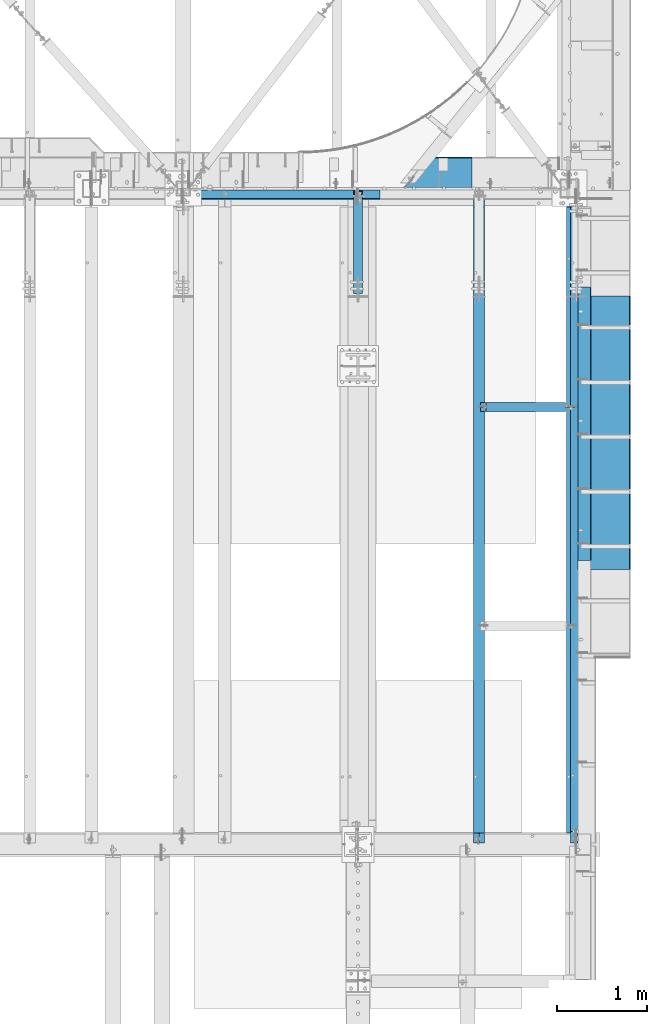
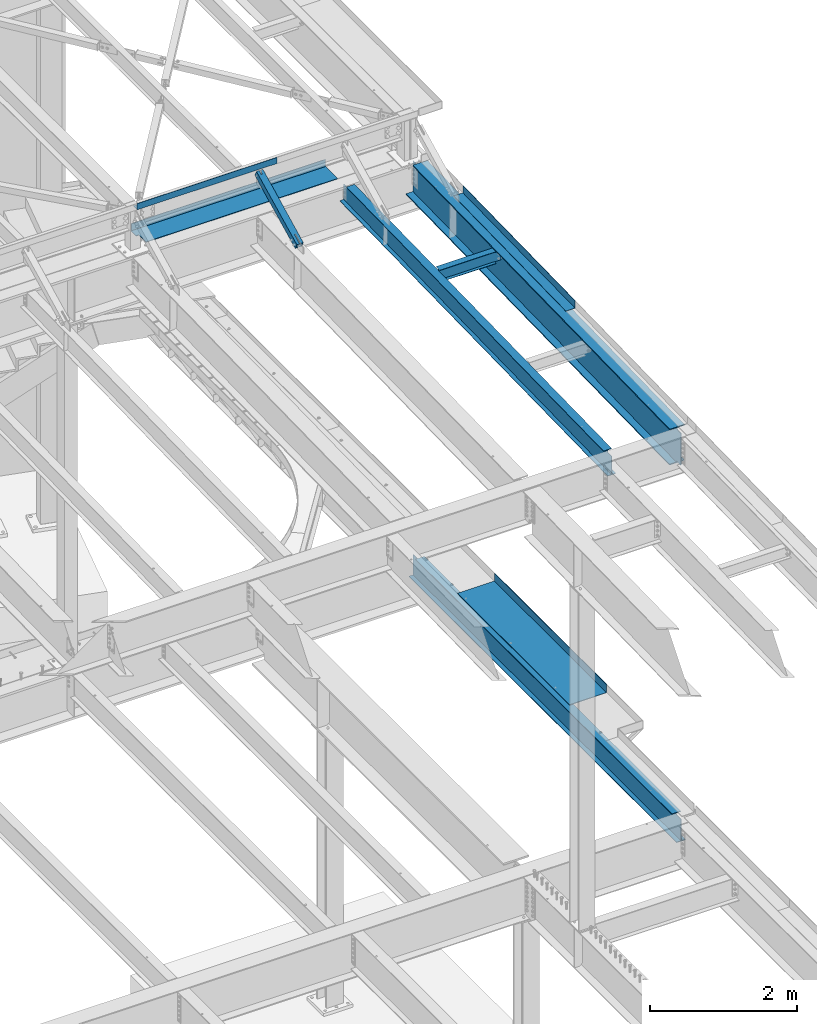
# One storey, part 1164 of 1763: 8 beams, 1 member, 7 elements without a shape of their own.
"""IFC2X3 building model written with IfcOpenShell, lengths in millimetres."""

from ifc_helpers import new_model, si_unit, frame, origin_with_axes, place, context, subcontext, project, spatial, faceted_brep, material, type_object, element, aggregate, save


model = new_model("IFC2X3")

# Units and contexts
model_context = context("Model", 3, precision=1e-05, world=origin_with_axes())
body_context = subcontext(model_context, "Body", "Model", "MODEL_VIEW")
ifc_project = project(units=[si_unit("LENGTHUNIT", "METRE", prefix="MILLI"), si_unit("AREAUNIT", "SQUARE_METRE"), si_unit("VOLUMEUNIT", "CUBIC_METRE"), si_unit("MASSUNIT", "GRAM", prefix="KILO"), si_unit("TIMEUNIT", "SECOND"), si_unit("PLANEANGLEUNIT", "RADIAN"), si_unit("SOLIDANGLEUNIT", "STERADIAN"), si_unit("THERMODYNAMICTEMPERATUREUNIT", "DEGREE_CELSIUS"), si_unit("LUMINOUSINTENSITYUNIT", "LUMEN")], contexts=[model_context])

# Site, building, storey
site_placement = place(None, origin_with_axes())
site = spatial("IfcSite", under=ifc_project, at=site_placement, CompositionType="ELEMENT")
building_placement = place(site_placement, origin_with_axes())
building = spatial("IfcBuilding", under=site, at=building_placement, Name="Undefined", CompositionType="ELEMENT")
storey_placement = place(building_placement, origin_with_axes())
storey = spatial("IfcBuildingStorey", under=building, at=storey_placement, Name="Undefined", CompositionType="ELEMENT", Elevation=0.0)

# Assembly, beam
assembly_1_placement = place(storey_placement, origin_with_axes())
assembly_1 = element("IfcElementAssembly", 1, at=assembly_1_placement, inside=storey, Name="BEAM", AssemblyPlace="NOTDEFINED", PredefinedType="RIGID_FRAME")
ifc_material_1 = material(Name="STEEL/A36")
beam_type_1 = type_object("IfcBeamType", Name="L4X4X1/4", PredefinedType="NOTDEFINED")
beam_1_placement = place(assembly_1_placement, frame((-25976.6096174484, 52050.95, 12496.8), z_axis=(0.0, 1.0, 0.0), x_axis=(1.0, 0.0, 0.0)))
beam_1 = element("IfcBeam", 2, at=beam_1_placement, type_object=beam_type_1, material=ifc_material_1, Name="V. BRACE", ObjectType="L4X4X1/4", context=body_context, shape_type="Brep", body=[
    faceted_brep([(-3.63797880709171e-11, 50.8000000000011, -50.8000000000538), (-1.96450855582952e-10, 50.8000000000393, 50.7999999999374), (2193.766250002, 50.7999999999993, 50.8000000000029), (2193.766250002, 50.7999999999993, -50.8000000000029), (-1.81898940354586e-10, 44.4500000000371, 50.7999999999374), (2193.766250002, 44.4500000000007, 50.8000000000029), (-2.18278728425503e-11, 44.4500000000007, -44.450000000048), (2193.766250002, 44.4500000000007, -44.4499999999971), (1.96450855582952e-10, -50.8000000000338, -44.4499999999534), (2193.766250002, -50.7999999999993, -44.4499999999971), (2.11002770811319e-10, -50.8000000000357, -50.799999999952), (2193.766250002, -50.7999999999993, -50.8000000000029)], [[[0, 1, 2, 3]], [[1, 4, 5, 2]], [[4, 6, 7, 5]], [[6, 8, 9, 7]], [[8, 10, 11, 9]], [[10, 0, 3, 11]], [[5, 7, 9, 11, 3, 2]], [[10, 8, 6, 4, 1, 0]]]),
])
aggregate(assembly_1, [beam_1])

assembly_2_placement = place(storey_placement, origin_with_axes())
assembly_2 = element("IfcElementAssembly", 3, at=assembly_2_placement, inside=storey, Name="BEAM", AssemblyPlace="NOTDEFINED", PredefinedType="RIGID_FRAME")
beam_type_2 = type_object("IfcBeamType", PredefinedType="NOTDEFINED")
beam_2_placement = place(assembly_2_placement, frame((-21576.7372736984, 49396.65, 5199.0625), z_axis=(0.0, -1.0, 0.0), x_axis=(1.0, 0.0, 0.0)))
beam_2 = element("IfcBeam", 4, at=beam_2_placement, type_object=beam_type_2, material=ifc_material_1, Name="BENT_PLATE", context=body_context, shape_type="Brep", body=[
    faceted_brep([(0.0, -4.76249999999982, -1524.0), (0.0, -4.76249999999982, 1524.0), (0.0, 4.76249999999982, 1524.0), (0.0, 4.76249999999982, -1524.0), (577.849999999999, 4.76249999999982, 1524.0), (577.849999999999, 4.76249999999982, -1524.0), (587.375, -4.76249999999982, -1524.0), (587.375, -4.76249999999982, 1524.0), (577.849999999999, 134.937496948242, 1524.0), (577.849999999999, 134.937496948242, -1524.0), (587.375, 134.937496948242, 1524.0), (587.375, 134.937496948242, -1524.0)], [[[0, 1, 2, 3]], [[3, 2, 4, 5]], [[1, 0, 6, 7]], [[5, 4, 8, 9]], [[4, 2, 1, 7, 10, 8]], [[7, 6, 11, 10]], [[6, 0, 3, 5, 9, 11]], [[10, 11, 9, 8]]]),
])

assembly_3_placement = place(storey_placement, origin_with_axes())
assembly_3 = element("IfcElementAssembly", 5, at=assembly_3_placement, inside=storey, Name="BEAM", AssemblyPlace="NOTDEFINED", PredefinedType="RIGID_FRAME")
ifc_material_2 = material(Name="STEEL/A992")
beam_type_3 = type_object("IfcBeamType", Name="W8X10", PredefinedType="NOTDEFINED")
beam_3_placement = place(assembly_3_placement, frame((-22673.3396174483, 49682.4, 11597.037837497), z_axis=(0.0, 0.0, 1.0), x_axis=(1.0, 0.0, 0.0)))
beam_3 = element("IfcBeam", 6, at=beam_3_placement, type_object=beam_type_3, material=ifc_material_2, Name="BEAM", ObjectType="W8X10", context=body_context, shape_type="Brep", body=[
    faceted_brep([(957.692640135556, 2.6814562411455, -95.25), (957.692640136163, 2.6810410749822, -100.012500000001), (957.692569353068, 50.8000000000029, -100.012500000001), (957.692569353068, 50.8000000000029, -95.25), (1065.64272309272, 2.68161503600277, -95.25), (1065.64272309272, 2.6811998698322, -100.012500000001), (74.2523437499622, 2.38124999999854, 95.25), (74.2523437499622, 50.8000000000029, 95.25), (956.898971566847, 50.8000000000029, 95.25), (956.898971566847, 2.38124999999854, 95.25), (74.2523437499622, -50.8000000000029, 100.012500000001), (74.2523437499622, 50.8000000000029, 100.012500000001), (74.2523437499622, 2.38124999999854, 80.7025014875653), (74.2523437499622, -2.38124999999854, 80.7025014875653), (74.2523437499622, -2.38124999999854, 95.25), (74.2523437499622, -50.8000000000029, 95.25), (73.2856138273746, 2.38124999999854, 75.8424219695189), (73.2856138273746, -2.38124999999854, 75.8424219695189), (70.5325999268971, 2.38124999999854, 71.7222455013653), (70.5325999268971, -2.38124999999854, 71.7222455013653), (66.4124234587434, 2.38124999999854, 68.9692316008877), (66.4124234587434, -2.38124999999854, 68.9692316008877), (61.552343940697, 2.38124999999854, 68.0025016783002), (61.552343940697, -2.38124999999854, 68.0025016783002), (10.7523437499694, 2.38124999999854, 68.0025016783002), (10.7523437499694, -2.38124999999854, 68.0025016783002), (10.7523437499694, 2.38124999999854, -95.25), (10.7523437499694, 50.8000000000029, -95.25), (10.7523437499694, 50.8000000000029, -100.012500000001), (10.7523437499694, -50.8000000000029, -100.012500000001), (10.7523437499694, -50.8000000000029, -95.25), (10.7523437499694, -2.38124999999854, -95.25), (957.692715737423, -50.8000000000029, -100.012500000001), (957.692715737423, -50.8000000000029, -95.25), (957.692644955085, -2.68145587174513, -100.012500000001), (957.692644954477, -2.68104070558184, -95.25), (1065.64272309272, -2.68088191115385, -95.25), (1065.64272309272, -2.68129707733169, -100.012500000001), (1065.64272309272, -2.38124999999854, -95.25), (969.598971376112, -2.38124999999854, 50.7402008918289), (965.540739476481, -2.38124999999854, 51.5474334063601), (964.738891858065, -2.38124999999854, 51.7069308144164), (960.618715389912, -2.38124999999854, 54.4599447148939), (957.865701489434, -2.38124999999854, 58.5801211830476), (956.898971566847, -2.38124999999854, 63.440200701094), (956.898971566847, -2.38124999999854, 95.25), (1065.64272309272, -2.38124999999854, 50.7402008918289), (970.392722901983, -2.38124999999854, 50.7402008918289), (956.898971566847, -50.8000000000029, 95.25), (956.898971566847, -50.8000000000029, 100.012500000001), (956.898971566847, 50.8000000000029, 100.012500000001), (956.898971566847, 2.38124999999854, 63.440200701094), (957.865701489434, 2.38124999999854, 58.5801211830476), (960.618715389912, 2.38124999999854, 54.4599447148939), (964.738891858065, 2.38124999999854, 51.7069308144164), (969.598971376112, 2.38124999999854, 50.7402008918289), (965.540739476481, 2.38124999999854, 51.5474334063601), (1065.64272309272, 2.38124999999854, 50.7402008918289), (970.392722901983, 2.38124999999854, 50.7402008918289), (1065.64272309272, 2.38124999999854, -95.25)], [[[0, 1, 2, 3]], [[4, 5, 1, 0]], [[6, 7, 8, 9]], [[10, 11, 7, 6, 12, 13, 14, 15]], [[13, 12, 16, 17]], [[17, 16, 18, 19]], [[19, 18, 20, 21]], [[21, 20, 22, 23]], [[23, 22, 24, 25]], [[26, 27, 28, 29, 30, 31, 25, 24]], [[30, 29, 32, 33]], [[33, 32, 34, 35]], [[36, 35, 34, 37]], [[38, 31, 30, 33, 35, 36]], [[39, 40, 41, 42, 43, 44, 45, 14, 13, 17, 19, 21, 23, 25, 31, 38, 46, 47]], [[15, 14, 45, 48]], [[10, 15, 48, 49]], [[11, 10, 49, 50]], [[7, 11, 50, 8]], [[49, 48, 45, 44, 51, 9, 8, 50]], [[43, 52, 51, 44]], [[42, 53, 52, 43]], [[41, 54, 53, 42]], [[40, 39, 55, 56, 54, 41]], [[47, 46, 57, 58, 55, 39]], [[57, 59, 26, 24, 22, 20, 18, 16, 12, 6, 9, 51, 52, 53, 54, 56, 55, 58]], [[3, 27, 26, 59, 4, 0]], [[28, 27, 3, 2]], [[37, 34, 32, 29, 28, 2, 1, 5]], [[59, 57, 46, 38, 36, 37, 5, 4]]]),
])
aggregate(assembly_3, [beam_3])

# Assembly, member
assembly_4_placement = place(storey_placement, origin_with_axes())
assembly_4 = element("IfcElementAssembly", 7, at=assembly_4_placement, inside=storey, Name="BEAM", AssemblyPlace="NOTDEFINED", PredefinedType="RIGID_FRAME")
ifc_material_3 = material()
member_type = type_object("IfcMemberType", Name="HSS4X4X1/2", PredefinedType="NOTDEFINED")
member_placement = place(assembly_4_placement, frame((-24027.8372736984, 50822.4762411266, 11720.6381213768), z_axis=(-1.0, 0.0, 0.0), x_axis=(0.0, 0.894427191199916, 0.447213595099959)))
member = element("IfcMember", 8, at=member_placement, type_object=member_type, material=ifc_material_3, Name="BEAM", ObjectType="HSS4X4X1/2", context=body_context, shape_type="Brep", body=[
    faceted_brep([(1394.22226894295, -50.8000000020184, -7.9375), (1394.2222689429, -38.1000000020122, -7.9375), (1321.53025774739, -38.1000000019103, -7.9375), (1327.88025774027, -50.8000000019219, -7.9375), (1321.53025774739, -38.1000000019103, 7.9375), (1327.88025774027, -50.8000000019219, 7.9375), (1394.22226894295, -50.8000000020184, 7.9375), (1394.2222689429, -38.1000000020122, 7.9375), (1394.22226894266, 38.0999999980304, -7.9375), (1394.22226894262, 50.799999998042, -7.9375), (1277.08025779721, 50.7999999982076, -7.9375), (1283.4302577901, 38.0999999981887, -7.9375), (1277.08025779721, 50.7999999982076, 7.9375), (1283.4302577901, 38.0999999981887, 7.9375), (1394.22226894266, 38.0999999980304, 7.9375), (1394.22226894262, 50.799999998042, 7.9375), (166.342448712407, -38.100000000255, 38.0999999999985), (166.342448712276, 38.0999999997875, 38.0999999999985), (1394.22226894266, 38.0999999980304, 38.0999999999985), (1394.2222689429, -38.1000000020122, 38.0999999999985), (1394.2222689429, -38.1000000020122, -38.0999999999985), (166.342448712407, -38.100000000255, -38.0999999999985), (166.342448712407, -38.100000000255, -7.93749999974898), (317.154945941751, -38.1000000004715, -7.93749999987267), (320.192495686126, -38.1000000004769, -7.33329378918279), (322.767606017376, -38.1000000004806, -5.61266007554514), (324.488239731007, -38.1000000004842, -3.03754974427284), (325.092445941693, -38.1000000004842, 2.5465851649642e-10), (324.488239731007, -38.1000000004842, 3.03754974465119), (322.767606017376, -38.1000000004806, 5.61266007592349), (320.192495686126, -38.1000000004788, 7.33329378956478), (317.154945941751, -38.1000000004733, 7.93750000025466), (166.342448712407, -38.100000000255, 7.93750000025466), (166.342448712276, 38.0999999997875, -38.0999999999985), (1394.22226894266, 38.0999999980304, -38.0999999999985), (166.342448712276, 38.0999999997875, 7.93750000025466), (166.342448712254, 50.7999999997955, 7.93750000025466), (317.154945941591, 50.7999999995791, 7.93750000025466), (317.15494594162, 38.0999999995711, 7.93750000025466), (320.192495685966, 50.7999999995736, 7.33329378956478), (320.192495685995, 38.0999999995693, 7.33329378956478), (322.767606017216, 50.7999999995718, 5.61266007592349), (322.767606017245, 38.0999999995638, 5.61266007592349), (324.488239730847, 50.7999999995682, 3.03754974465119), (324.488239730868, 38.0999999995638, 3.03754974465119), (325.092445941533, 50.7999999995682, 2.5465851649642e-10), (325.092445941555, 38.0999999995583, 2.5465851649642e-10), (324.488239730847, 50.7999999995682, -3.03754974427284), (324.488239730861, 38.0999999995602, -3.03754974427284), (322.767606017209, 50.79999999957, -5.61266007554514), (322.767606017245, 38.0999999995638, -5.61266007554514), (320.192495685966, 50.7999999995754, -7.33329378918279), (320.19249568598, 38.0999999995674, -7.33329378918279), (317.154945941591, 50.7999999995791, -7.93749999987267), (317.154945941606, 38.0999999995693, -7.93749999987267), (166.342448712254, 50.7999999997955, -7.93749999974898), (166.342448712276, 38.0999999997875, -7.93749999974898), (166.342448712254, 50.7999999997955, -50.7999999999993), (166.342448712421, -50.8000000002612, -50.7999999999993), (166.342448712421, -50.8000000002612, -7.93749999974898), (317.154945941773, -50.8000000004795, -7.93749999987267), (320.192495686155, -50.8000000004831, -7.33329378918279), (322.767606017391, -50.8000000004868, -5.61266007554514), (324.488239731028, -50.800000000494, -3.03754974427284), (325.092445941715, -50.8000000004904, 2.5465851649642e-10), (324.488239731028, -50.800000000494, 3.03754974465119), (322.767606017405, -50.8000000004849, 5.61266007592349), (320.192495686155, -50.8000000004849, 7.33329378956478), (317.154945941787, -50.8000000004795, 7.93750000025466), (166.342448712421, -50.8000000002612, 7.93750000025466), (166.342448712421, -50.8000000002612, 50.7999999999993), (166.342448712254, 50.7999999997955, 50.7999999999993), (1394.22226894295, -50.8000000020184, 50.7999999999993), (1394.22226894262, 50.799999998042, 50.7999999999993), (1394.22226894262, 50.799999998042, -50.7999999999993), (1394.22226894295, -50.8000000020184, -50.7999999999993)], [[[0, 1, 2, 3]], [[3, 2, 4, 5]], [[6, 5, 4, 7]], [[8, 9, 10, 11]], [[11, 10, 12, 13]], [[14, 13, 12, 15]], [[16, 17, 18, 19]], [[2, 1, 20, 21, 22, 23, 24, 25, 26, 27, 28, 29, 30, 31, 32, 16, 19, 7, 4]], [[33, 21, 20, 34]], [[35, 36, 37, 38]], [[38, 37, 39, 40]], [[40, 39, 41, 42]], [[42, 41, 43, 44]], [[44, 43, 45, 46]], [[46, 45, 47, 48]], [[48, 47, 49, 50]], [[50, 49, 51, 52]], [[52, 51, 53, 54]], [[54, 53, 55, 56]], [[21, 33, 56, 55, 57, 58, 59, 22]], [[60, 23, 22, 59]], [[61, 24, 23, 60]], [[62, 25, 24, 61]], [[63, 26, 25, 62]], [[64, 27, 26, 63]], [[65, 28, 27, 64]], [[66, 29, 28, 65]], [[67, 30, 29, 66]], [[68, 31, 30, 67]], [[69, 32, 31, 68]], [[70, 71, 36, 35, 17, 16, 32, 69]], [[71, 70, 72, 73]], [[19, 18, 14, 15, 73, 72, 6, 7]], [[10, 9, 74, 57, 55, 53, 51, 49, 47, 45, 43, 41, 39, 37, 36, 71, 73, 15, 12]], [[58, 57, 74, 75]], [[72, 70, 69, 68, 67, 66, 65, 64, 63, 62, 61, 60, 59, 58, 75, 0, 3, 5, 6]], [[75, 74, 9, 8, 34, 20, 1, 0]], [[18, 17, 35, 38, 40, 42, 44, 46, 48, 50, 52, 54, 56, 33, 34, 8, 11, 13, 14]]]),
])
aggregate(assembly_4, [member])

# Assembly, beam
assembly_5_placement = place(storey_placement, origin_with_axes())
assembly_5 = element("IfcElementAssembly", 9, at=assembly_5_placement, inside=storey, Name="BEAM", AssemblyPlace="NOTDEFINED", PredefinedType="RIGID_FRAME")
beam_type_4 = type_object("IfcBeamType", Name="W14X22", PredefinedType="NOTDEFINED")
beam_4_placement = place(assembly_5_placement, frame((-22678.4622736984, 44809.2121579121, 11421.5633921212), z_axis=(0.0, -0.0206852279954837, 0.999786037781472), x_axis=(0.0, 0.999786037781472, 0.0206852279954825)))
beam_4 = element("IfcBeam", 10, at=beam_4_placement, type_object=beam_type_4, material=ifc_material_2, Name="BEAM", ObjectType="W14X22", context=body_context, shape_type="Brep", body=[
    faceted_brep([(116.24722620719, -3.17499999999927, 136.265001678286), (116.24722620719, 3.17499999999927, 136.265001678286), (17.4665018602245, 3.17499999999927, 136.265001678306), (17.4665018602245, -3.17499999999927, 136.265001678306), (121.10730572528, -3.17499999999927, 137.231731600872), (121.10730572528, 3.17499999999927, 137.231731600872), (125.227482193462, -3.17499999999927, 139.984745501344), (125.227482193462, 3.17499999999927, 139.984745501344), (127.980496093973, -3.17499999999927, 144.104921969487), (127.980496093973, 3.17499999999927, 144.104921969487), (128.947226016564, -3.17499999999927, 148.965001487522), (128.947226016564, 3.17499999999927, 148.965001487522), (128.947226016564, -63.5, 174.624999999836), (128.947226016564, 63.5, 174.624999999836), (128.947226016571, 63.5, 166.687499999842), (128.947226016571, 3.17499999999927, 166.687499999842), (128.947226016571, -3.17499999999927, 166.687499999842), (128.947226016571, -63.5, 166.687499999842), (11.1985191797066, -3.17499999999927, -166.687499999876), (11.1985191797066, -63.5, -166.687499999876), (7286.68019766203, -63.5, -166.687500001812), (7286.68019766203, -3.17499999999927, -166.687500001812), (11.0342950447375, -63.5, -174.624999999869), (7286.51597352705, -63.5, -174.625000001804), (11.0342950447375, 63.5, -174.624999999869), (7286.51597352705, 63.5, -174.625000001804), (11.1985191797066, 63.5, -166.687499999876), (7286.68019766203, 63.5, -166.687500001812), (11.1985191797066, 3.17499999999927, -166.687499999876), (7286.68019766203, 3.17499999999927, -166.687500001812), (7292.02852510755, 3.17499999999927, 91.8149978515976), (7292.02852510755, -3.17499999999927, 91.8149978515976), (7125.028904344, 3.17499999999927, 91.8149978516285), (7125.028904344, -3.17499999999927, 91.8149978516285), (7120.16882482591, 3.17499999999927, 92.7817277742161), (7120.16882482591, -3.17499999999927, 92.7817277742161), (7116.04864835773, 3.17499999999927, 95.5347416746881), (7116.04864835773, -3.17499999999927, 95.5347416746881), (7113.29563445722, 3.17499999999927, 99.6549181428345), (7113.29563445722, -3.17499999999927, 99.6549181428345), (7112.32890453462, 3.17499999999927, 104.51499766087), (7112.32890453462, -3.17499999999927, 104.51499766087), (7112.32890453463, -63.5, 174.624999997979), (7112.32890453462, -63.5, 166.687499997985), (7112.32890453462, -3.17499999999927, 166.687499997985), (7112.32890453462, 3.17499999999927, 166.687499997985), (7112.32890453462, 63.5, 166.687499997985), (7112.32890453463, 63.5, 174.624999997979)], [[[0, 1, 2, 3]], [[4, 5, 1, 0]], [[6, 7, 5, 4]], [[8, 9, 7, 6]], [[10, 11, 9, 8]], [[12, 13, 14, 15, 11, 10, 16, 17]], [[18, 19, 20, 21]], [[19, 22, 23, 20]], [[22, 24, 25, 23]], [[24, 26, 27, 25]], [[26, 28, 29, 27]], [[21, 20, 23, 25, 27, 29, 30, 31]], [[31, 30, 32, 33]], [[33, 32, 34, 35]], [[35, 34, 36, 37]], [[37, 36, 38, 39]], [[39, 38, 40, 41]], [[42, 43, 44, 41, 40, 45, 46, 47]], [[43, 42, 12, 17]], [[44, 43, 17, 16]], [[8, 6, 4, 0, 3, 18, 21, 31, 33, 35, 37, 39, 41, 44, 16, 10]], [[28, 26, 24, 22, 19, 18, 3, 2]], [[45, 40, 38, 36, 34, 32, 30, 29, 28, 2, 1, 5, 7, 9, 11, 15]], [[46, 45, 15, 14]], [[47, 46, 14, 13]], [[42, 47, 13, 12]]]),
])
aggregate(assembly_5, [beam_4])

assembly_6_placement = place(storey_placement, origin_with_axes())
assembly_6 = element("IfcElementAssembly", 11, at=assembly_6_placement, inside=storey, Name="BEAM", AssemblyPlace="NOTDEFINED", PredefinedType="RIGID_FRAME")
beam_type_5 = type_object("IfcBeamType", PredefinedType="NOTDEFINED")
beam_5_placement = place(assembly_6_placement, frame((-24278.6617736984, 52133.5000002128, 11752.2624917654), z_axis=(-1.0, 0.0, 0.0), x_axis=(0.0, 1.0, 0.0)))
beam_5 = element("IfcBeam", 12, at=beam_5_placement, type_object=beam_type_5, material=ifc_material_1, Name="BENT_PLATE", context=body_context, shape_type="Brep", body=[
    faceted_brep([(193.674999999981, -4.76250000000073, 1482.0478521423), (193.674999999981, 4.76250000000073, 1482.0478521423), (0.0, 4.76250000000073, 1482.0478521423), (0.0, -4.76250000000073, 1482.0478521423), (193.674999999974, -4.76250000000073, 1523.99998913571), (193.674999999974, 4.76250000000073, 1524.0), (327.024987792975, -4.76250000000073, -1524.0), (0.0, -4.76249999999982, -1524.0), (0.0, 4.76249999999982, -1524.0), (336.549987792969, 4.76250000000073, -1524.0), (336.549987792969, -122.237499999999, -1524.0), (327.024987792975, -122.237499999999, -1524.0), (336.549987792969, 4.76250000000073, 1524.0), (336.549987792969, -122.237499999999, 1524.0), (327.024987792975, -122.237499999999, 1524.0), (327.024987792967, -4.76250000000073, 1524.00000000001)], [[[0, 1, 2, 3]], [[4, 5, 1, 0]], [[6, 7, 8, 9, 10, 11]], [[9, 12, 13, 10]], [[14, 11, 10, 13]], [[15, 6, 11, 14]], [[3, 7, 6, 15, 4, 0]], [[8, 7, 3, 2]], [[12, 9, 8, 2, 1, 5]], [[15, 14, 13, 12, 5, 4]]]),
])
aggregate(assembly_6, [beam_5])

# Assembly, beams
assembly_7_placement = place(storey_placement, origin_with_axes())
assembly_7 = element("IfcElementAssembly", 13, at=assembly_7_placement, inside=storey, Name="BEAM", AssemblyPlace="NOTDEFINED", PredefinedType="RIGID_FRAME")
beam_type_6 = type_object("IfcBeamType", PredefinedType="NOTDEFINED")
beam_6_placement = place(assembly_7_placement, frame((-21576.7406443556, 49497.3265728792, 11696.3969116519), z_axis=(0.0, -0.999786037781472, -0.0206852279954809), x_axis=(1.0, 0.0, 0.0)))
beam_6 = element("IfcBeam", 14, at=beam_6_placement, type_object=beam_type_6, material=ifc_material_1, Name="BENT_PLATE", context=body_context, shape_type="Brep", body=[
    faceted_brep([(0.0, -3.17499999999927, -1523.99999999999), (0.0, -3.17499999999927, 1524.0), (0.0, 3.17499999999927, 1524.0), (0.0, 3.17499999999927, -1523.99999999999), (142.87500610367, 3.17500000040309, 1524.00000000439), (142.875006103837, 3.17499999959364, -1524.00000000439), (149.225006103836, -3.17500000040127, -1524.00000000439), (149.225006103668, -3.17499999959364, 1524.00000000439), (142.875006103754, 123.824997298818, 1524.00000000437), (142.875006103754, 123.824997298098, -1524.00000000442), (149.225006103752, 123.824997298818, 1524.00000000437), (149.225006103752, 123.824997298098, -1524.00000000442)], [[[0, 1, 2, 3]], [[3, 2, 4, 5]], [[1, 0, 6, 7]], [[5, 4, 8, 9]], [[4, 2, 1, 7, 10, 8]], [[7, 6, 11, 10]], [[6, 0, 3, 5, 9, 11]], [[10, 11, 9, 8]]]),
])
beam_type_7 = type_object("IfcBeamType", Name="W24X76", PredefinedType="NOTDEFINED")
beam_7_placement = place(assembly_7_placement, frame((-21589.4406443556, 44811.8720196139, 11293.0034049881), z_axis=(0.0, -0.0206852279954837, 0.999786037781472), x_axis=(0.0, 0.999786037781472, 0.0206852279954825)))
beam_7 = element("IfcBeam", 15, at=beam_7_placement, type_object=beam_type_7, material=ifc_material_2, Name="BEAM", ObjectType="W24X76", context=body_context, shape_type="Brep", body=[
    faceted_brep([(6.49632960907184, -5.55625000000146, -265.372499999168), (6.49632960907184, 5.55625000000146, -265.372499999168), (113.586795220392, 5.55625000000146, -265.372499999228), (113.586795220392, -5.55625000000146, -265.372499999228), (118.446874738482, 5.55625000000146, -266.339229921816), (118.446874738482, -5.55625000000146, -266.339229921816), (122.567051206664, 5.55625000000146, -269.092243822288), (122.567051206664, -5.55625000000146, -269.092243822288), (125.32006510716, 5.55625000000146, -273.212420290434), (125.32006510716, -5.55625000000146, -273.212420290434), (126.286795029759, -5.55625000000146, -278.07249980847), (126.286795029759, 5.55625000000146, -278.07249980847), (126.286795029759, 5.55625000000146, -285.749999999816), (126.286795029759, 114.299999999999, -285.749999999816), (126.286795029751, 114.299999999999, -303.212499999803), (126.286795029751, -114.299999999999, -303.212499999803), (126.286795029759, -114.299999999999, -285.749999999816), (126.286795029759, -5.55625000000146, -285.749999999816), (126.286795029817, 5.55625000000146, 285.749999999754), (126.286795029817, 114.299999999999, 285.749999999754), (7109.66847354787, 114.299999999999, 285.749999997897), (7109.66847354787, 5.55625000000146, 285.749999997897), (113.58679522045, -5.55625000000146, 264.852501677899), (113.58679522045, 5.55625000000146, 264.852501677899), (17.4665018600936, 5.55625000000146, 264.852501677915), (17.4665018600936, -5.55625000000146, 264.852501677915), (118.446874738533, -5.55625000000146, 265.819231600481), (118.446874738533, 5.55625000000146, 265.819231600481), (122.567051206723, -5.55625000000146, 268.572245500953), (122.567051206723, 5.55625000000146, 268.572245500953), (125.320065107226, -5.55625000000146, 272.692421969095), (125.320065107226, 5.55625000000146, 272.692421969095), (126.286795029824, -5.55625000000146, 277.552501487131), (126.286795029824, 5.55625000000146, 277.552501487131), (126.286795029817, -114.299999999999, 303.212499999741), (126.286795029817, 114.299999999999, 303.212499999741), (126.286795029817, -5.55625000000146, 285.749999999754), (126.286795029817, -114.299999999999, 285.749999999754), (7109.66847354787, -5.55625000000146, 285.749999997897), (7109.66847354787, -114.299999999999, 285.749999997897), (7109.66847354788, -114.299999999999, 303.212499997884), (7109.66847354788, 114.299999999999, 303.212499997884), (7109.66847354787, -5.55625000000146, 233.102497660489), (7109.66847354787, 5.55625000000146, 233.102497660489), (7110.63520347048, -5.55625000000146, 228.242418142454), (7110.63520347048, 5.55625000000146, 228.242418142454), (7113.38821737097, -5.55625000000146, 224.122241674309), (7113.38821737097, 5.55625000000146, 224.122241674309), (7117.50839383915, -5.55625000000146, 221.369227773837), (7117.50839383915, 5.55625000000146, 221.369227773837), (7122.36847335724, -5.55625000000146, 220.402497851248), (7122.36847335724, 5.55625000000146, 220.402497851248), (7292.02852510743, -5.55625000000146, 220.402497851217), (7292.02852510743, 5.55625000000146, 220.402497851217), (7281.55640465069, -5.55625000000146, -285.750000001717), (7281.55640465069, -114.299999999999, -285.750000001717), (7281.19511155374, -114.299999999999, -303.212500001704), (7281.19511155374, 114.299999999999, -303.212500001704), (7281.55640465069, 114.299999999999, -285.750000001717), (7281.55640465069, 5.55625000000146, -285.750000001717)], [[[0, 1, 2, 3]], [[3, 2, 4, 5]], [[5, 4, 6, 7]], [[7, 6, 8, 9]], [[10, 11, 12, 13, 14, 15, 16, 17]], [[9, 8, 11, 10]], [[18, 19, 20, 21]], [[22, 23, 24, 25]], [[26, 27, 23, 22]], [[28, 29, 27, 26]], [[30, 31, 29, 28]], [[32, 33, 31, 30]], [[34, 35, 19, 18, 33, 32, 36, 37]], [[37, 36, 38, 39]], [[34, 37, 39, 40]], [[35, 34, 40, 41]], [[19, 35, 41, 20]], [[40, 39, 38, 42, 43, 21, 20, 41]], [[44, 45, 43, 42]], [[46, 47, 45, 44]], [[48, 49, 47, 46]], [[50, 51, 49, 48]], [[52, 53, 51, 50]], [[54, 55, 56, 57, 58, 59, 53, 52]], [[55, 54, 17, 16]], [[56, 55, 16, 15]], [[57, 56, 15, 14]], [[58, 57, 14, 13]], [[59, 58, 13, 12]], [[6, 4, 2, 1, 24, 23, 27, 29, 31, 33, 18, 21, 43, 45, 47, 49, 51, 53, 59, 12, 11, 8]], [[25, 24, 1, 0]], [[54, 52, 50, 48, 46, 44, 42, 38, 36, 32, 30, 28, 26, 22, 25, 0, 3, 5, 7, 9, 10, 17]]]),
])
aggregate(assembly_7, [beam_6, beam_7])

# Beam
beam_type_8 = type_object("IfcBeamType", Name="W16X31", PredefinedType="NOTDEFINED")
beam_8_placement = place(assembly_2_placement, frame((-21589.4372736984, 44805.6, 4992.6875), z_axis=(0.0, 0.0, 1.0), x_axis=(0.0, 1.0, 0.0)))
beam_8 = element("IfcBeam", 16, at=beam_8_placement, type_object=beam_type_8, material=ifc_material_2, Name="BEAM", ObjectType="W16X31", context=body_context, shape_type="Brep", body=[
    faceted_brep([(133.349999433754, -3.17499999999927, 169.602501678466), (133.349999433754, 3.17499999999927, 169.602501678466), (19.0499999999956, 3.17499999999927, 169.602501678466), (19.0499999999956, -3.17499999999927, 169.602501678466), (138.210078951801, -3.17499999999927, 170.569231601054), (138.210078951801, 3.17499999999927, 170.569231601054), (142.330255419954, -3.17499999999927, 173.322245501532), (142.330255419954, 3.17499999999927, 173.322245501532), (145.083269320428, -3.17499999999927, 177.442421969686), (145.083269320428, 3.17499999999927, 177.442421969686), (146.04999924302, -3.17499999999927, 182.302501487731), (146.04999924302, 3.17499999999927, 182.302501487731), (146.04999924302, -69.8499999999985, 201.6125), (146.04999924302, 69.8499999999985, 201.6125), (146.04999924302, 69.8499999999985, 190.5), (146.04999924302, 3.17499999999927, 190.5), (146.04999924302, -3.17499999999927, 190.5), (146.04999924302, -69.8499999999985, 190.5), (19.0499999999956, -3.17499999999927, -190.5), (19.0499999999956, -69.8499999999985, -190.5), (7292.18125, -69.8499999999985, -190.5), (7292.18125, -3.17499999999927, -190.5), (19.0499999999956, -69.8499999999985, -201.6125), (7292.18125, -69.8499999999985, -201.6125), (19.0499999999956, 69.8499999999985, -201.6125), (7292.18125, 69.8499999999985, -201.6125), (19.0499999999956, 69.8499999999985, -190.5), (7292.18125, 69.8499999999985, -190.5), (19.0499999999956, 3.17499999999927, -190.5), (7292.18125, 3.17499999999927, -190.5), (7292.18125, 3.17499999999927, 144.202497863769), (7292.18125, -3.17499999999927, 144.202497863769), (7120.73124980927, 3.17499999999927, 144.202497863769), (7120.73124980927, -3.17499999999927, 144.202497863769), (7115.87117029122, 3.17499999999927, 145.169227786357), (7115.87117029122, -3.17499999999927, 145.169227786357), (7111.75099382307, 3.17499999999927, 147.922241686835), (7111.75099382307, -3.17499999999927, 147.922241686835), (7108.99797992258, 3.17499999999927, 152.042418154989), (7108.99797992258, -3.17499999999927, 152.042418154989), (7108.03125, 3.17499999999927, 156.902497673034), (7108.03125, -3.17499999999927, 156.902497673034), (7108.03125, -69.8499999999985, 201.6125), (7108.03125, -69.8499999999985, 190.5), (7108.03125, -3.17499999999927, 190.5), (7108.03125, 3.17499999999927, 190.5), (7108.03125, 69.8499999999985, 190.5), (7108.03125, 69.8499999999985, 201.6125)], [[[0, 1, 2, 3]], [[4, 5, 1, 0]], [[6, 7, 5, 4]], [[8, 9, 7, 6]], [[10, 11, 9, 8]], [[12, 13, 14, 15, 11, 10, 16, 17]], [[18, 19, 20, 21]], [[19, 22, 23, 20]], [[22, 24, 25, 23]], [[24, 26, 27, 25]], [[26, 28, 29, 27]], [[21, 20, 23, 25, 27, 29, 30, 31]], [[31, 30, 32, 33]], [[33, 32, 34, 35]], [[35, 34, 36, 37]], [[37, 36, 38, 39]], [[39, 38, 40, 41]], [[42, 43, 44, 41, 40, 45, 46, 47]], [[43, 42, 12, 17]], [[44, 43, 17, 16]], [[8, 6, 4, 0, 3, 18, 21, 31, 33, 35, 37, 39, 41, 44, 16, 10]], [[28, 26, 24, 22, 19, 18, 3, 2]], [[45, 40, 38, 36, 34, 32, 30, 29, 28, 2, 1, 5, 7, 9, 11, 15]], [[46, 45, 15, 14]], [[47, 46, 14, 13]], [[42, 47, 13, 12]]]),
])

aggregate(assembly_2, [beam_2, beam_8])

save(model, "model.ifc")
